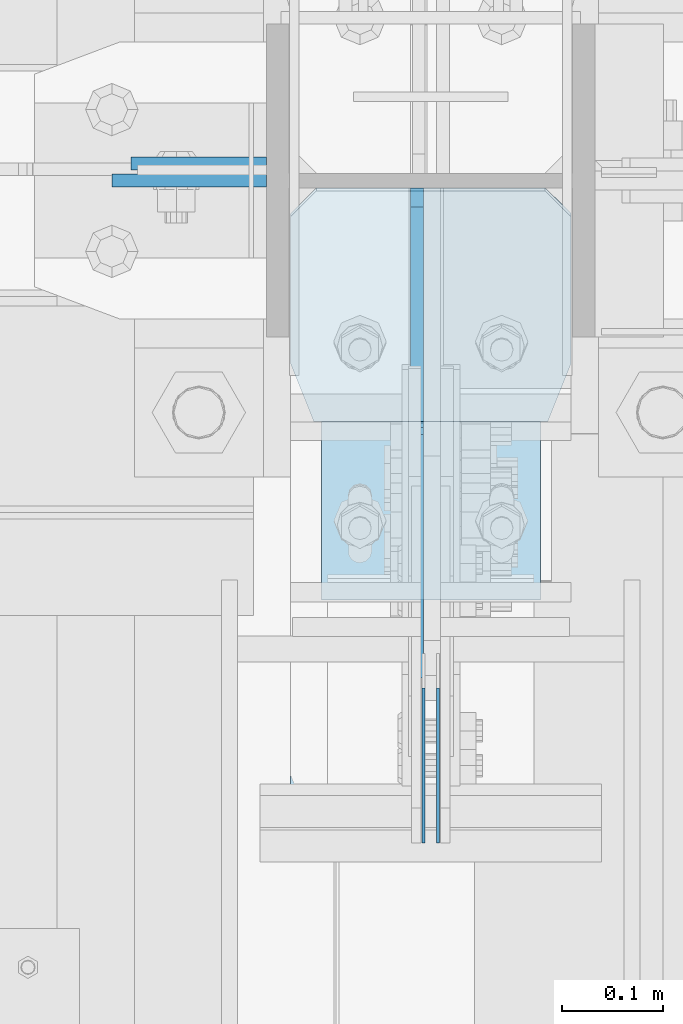
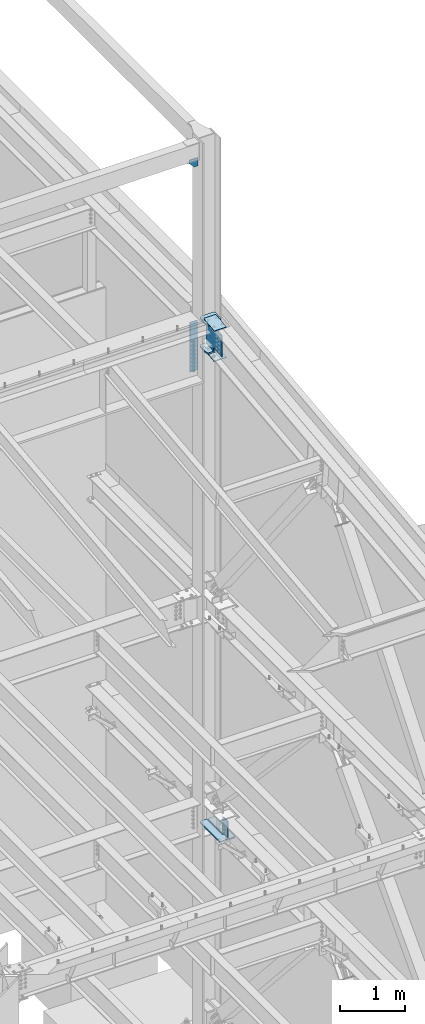
# One storey, part 1089 of 1179: 10 plates, 2 elements without a shape of their own.
"""IFC2X3 building model written with IfcOpenShell, lengths in millimetres."""

from ifc_helpers import new_model, si_unit, frame, origin_with_axes, place, context, subcontext, project, spatial, faceted_brep, material, type_object, element, aggregate, save


model = new_model("IFC2X3")

# Units and contexts
model_context = context("Model", 3, precision=1e-05, world=origin_with_axes())
body_context = subcontext(model_context, "Body", "Model", "MODEL_VIEW")
ifc_project = project(units=[si_unit("LENGTHUNIT", "METRE", prefix="MILLI"), si_unit("AREAUNIT", "SQUARE_METRE"), si_unit("VOLUMEUNIT", "CUBIC_METRE"), si_unit("MASSUNIT", "GRAM", prefix="KILO"), si_unit("TIMEUNIT", "SECOND"), si_unit("PLANEANGLEUNIT", "RADIAN"), si_unit("SOLIDANGLEUNIT", "STERADIAN"), si_unit("THERMODYNAMICTEMPERATUREUNIT", "DEGREE_CELSIUS"), si_unit("LUMINOUSINTENSITYUNIT", "LUMEN")], contexts=[model_context])

# Site, building, storey
site_placement = place(None, origin_with_axes())
site = spatial("IfcSite", under=ifc_project, at=site_placement, CompositionType="ELEMENT")
building_placement = place(site_placement, origin_with_axes())
building = spatial("IfcBuilding", under=site, at=building_placement, Name="Undefined", CompositionType="ELEMENT")
storey_placement = place(building_placement, origin_with_axes())
storey = spatial("IfcBuildingStorey", under=building, at=storey_placement, Name="Undefined", CompositionType="ELEMENT", Elevation=0.0)

# Assembly, plates
assembly_1_placement = place(storey_placement, origin_with_axes())
assembly_1 = element("IfcElementAssembly", 1, at=assembly_1_placement, inside=storey, Name="BEAM", AssemblyPlace="NOTDEFINED", PredefinedType="RIGID_FRAME")
ifc_material_1 = material(Name="STEEL/A572-GR.50")
plate_type_1 = type_object("IfcPlateType", PredefinedType="NOTDEFINED")
plate_1_placement = place(assembly_1_placement, frame((24300.65625, 33738.9169989339, 4044.95), z_axis=(0.0, 0.0, -1.0), x_axis=(0.0, 1.0, 0.0)))
plate_1 = element("IfcPlate", 2, at=plate_1_placement, type_object=plate_type_1, material=ifc_material_1, Name="PLATE", context=body_context, shape_type="Brep", body=[
    faceted_brep([(3.63797880709171e-12, -1.58750000000055, 1.81898940354586e-12), (-2.18278728425503e-11, -1.58750000000146, 304.8), (-2.18278728425503e-11, 1.58750000000146, 304.8), (-3.63797880709171e-12, 1.58750000000055, 0.0), (152.399999999994, -1.58750000000146, 304.8), (152.399999999994, 1.58750000000146, 304.8), (152.399999999994, -1.58750000000146, 0.0), (152.399999999994, 1.58750000000146, 0.0)], [[[0, 1, 2, 3]], [[1, 4, 5, 2]], [[4, 6, 7, 5]], [[6, 0, 3, 7]], [[5, 7, 3, 2]], [[6, 4, 1, 0]]]),
])
plate_2_placement = place(assembly_1_placement, frame((24314.94375, 33738.9169989339, 4044.95), z_axis=(0.0, 0.0, -1.0), x_axis=(0.0, 1.0, 0.0)))
plate_2 = element("IfcPlate", 3, at=plate_2_placement, type_object=plate_type_1, material=ifc_material_1, Name="PLATE", context=body_context, shape_type="Brep", body=[
    faceted_brep([(3.63797880709171e-12, -1.58750000000055, 1.81898940354586e-12), (-2.18278728425503e-11, -1.58750000000146, 304.8), (-2.18278728425503e-11, 1.58750000000146, 304.8), (-3.63797880709171e-12, 1.58750000000055, 0.0), (152.399999999994, -1.58750000000146, 304.8), (152.399999999994, 1.58750000000146, 304.8), (152.399999999994, -1.58750000000146, 0.0), (152.399999999994, 1.58750000000146, 0.0)], [[[0, 1, 2, 3]], [[1, 4, 5, 2]], [[4, 6, 7, 5]], [[6, 0, 3, 7]], [[5, 7, 3, 2]], [[6, 4, 1, 0]]]),
])
aggregate(assembly_1, [plate_1, plate_2])

assembly_2_placement = place(storey_placement, origin_with_axes())
assembly_2 = element("IfcElementAssembly", 4, at=assembly_2_placement, inside=storey, Name="COLUMN", AssemblyPlace="NOTDEFINED", PredefinedType="RIGID_FRAME")
ifc_material_2 = material(Name="STEEL/A36")
plate_type_2 = type_object("IfcPlateType", PredefinedType="NOTDEFINED")
plate_3_placement = place(assembly_2_placement, frame((23993.4750001183, 34391.6, 16109.95), z_axis=(1.0, 0.0, 0.0), x_axis=(0.0, 0.0, -1.0)))
plate_3 = element("IfcPlate", 5, at=plate_3_placement, type_object=plate_type_2, material=ifc_material_2, Name="PLATE", context=body_context, shape_type="Brep", body=[
    faceted_brep([(0.0, -6.34999999999854, 0.0), (0.0, -6.34999999999854, 152.400000000001), (0.0, 6.34999999999854, 152.400000000001), (0.0, 6.34999999999854, 0.0), (152.399993896484, -6.34999999999854, 152.399993896484), (152.399993896484, 6.34999999999854, 152.399993896484), (152.399993896484, -6.34999999999854, 88.6901931762695), (152.399993896484, 6.34999999999854, 88.6901931762695), (63.5, -6.34999999999854, 0.0), (63.5, 6.34999999999854, 0.0)], [[[0, 1, 2, 3]], [[1, 4, 5, 2]], [[4, 6, 7, 5]], [[6, 8, 9, 7]], [[8, 0, 3, 9]], [[5, 7, 9, 3, 2]], [[8, 6, 4, 1, 0]]]),
])
plate_type_3 = type_object("IfcPlateType", PredefinedType="NOTDEFINED")
plate_4_placement = place(assembly_2_placement, frame((24169.6874938965, 33751.6169989338, 3694.1125), z_axis=(0.0, 1.0, 0.0), x_axis=(1.0, 0.0, 0.0)))
plate_4 = element("IfcPlate", 6, at=plate_4_placement, type_object=plate_type_3, material=ifc_material_1, Name="PLATE", context=body_context, shape_type="Brep", body=[
    faceted_brep([(127.000006103513, -11.1125000000002, 632.839251066151), (127.000006103513, -11.1125000000002, 153.987500190735), (127.000006103513, 11.1125000000002, 153.987500190735), (127.000006103513, 11.1125000000002, 632.839251066151), (127.845894812999, -11.1125000000002, 149.734930475584), (127.845894812999, 11.1125000000002, 149.734930475584), (130.254782053442, -11.1125000000002, 146.129775949928), (130.254782053442, 11.1125000000002, 146.129775949928), (133.859936579101, -11.1125000000002, 143.720888709489), (133.859936579101, 11.1125000000002, 143.720888709489), (138.112505912784, -11.1125000000002, 142.875), (138.112505912784, 11.1125000000002, 142.875), (142.365075627931, -11.1125000000002, 143.720888709489), (142.365075627931, 11.1125000000002, 143.720888709489), (145.970230153591, -11.1125000000002, 146.129775949928), (145.970230153591, 11.1125000000002, 146.129775949928), (148.379117394034, -11.1125000000002, 149.734930475584), (148.379117394034, 11.1125000000002, 149.734930475584), (149.225006103519, -11.1125000000002, 153.987500190735), (149.225006103519, 11.1125000000002, 153.987500190735), (149.225006103519, -11.1125000000002, 632.839251066151), (149.225006103519, 11.1125000000002, 632.839251066151), (0.0, -11.1125000000002, 607.43925144762), (25.3999996185303, -11.1125000000002, 632.839251066151), (25.3999996185303, 11.1125000000002, 632.839251066151), (0.0, 11.1125000000002, 607.43925144762), (0.0, -11.1125000000002, 19.0499992370605), (0.0, 11.1125000000002, 19.0499992370605), (7.9375, -11.1125000000002, 0.0), (7.9375, 11.1125000000002, 0.0), (268.287506103516, -11.1125000000002, 0.0), (268.287506103516, 11.1125000000002, 0.0), (276.225006103516, -11.1125000000002, 19.0499992370605), (276.225006103516, 11.1125000000002, 19.0499992370605), (276.225006103516, -11.1125000000002, 607.43925144762), (276.225006103516, 11.1125000000002, 607.43925144762), (250.825006484985, -11.1125000000002, 632.839251066151), (250.825006484985, 11.1125000000002, 632.839251066151)], [[[0, 1, 2, 3]], [[4, 5, 2, 1]], [[6, 7, 5, 4]], [[8, 9, 7, 6]], [[10, 11, 9, 8]], [[12, 13, 11, 10]], [[14, 15, 13, 12]], [[16, 17, 15, 14]], [[18, 19, 17, 16]], [[20, 21, 19, 18]], [[22, 23, 24, 25]], [[26, 22, 25, 27]], [[28, 26, 27, 29]], [[30, 28, 29, 31]], [[32, 30, 31, 33]], [[34, 32, 33, 35]], [[36, 34, 35, 37]], [[16, 14, 12, 10, 8, 6, 4, 1, 0, 23, 22, 26, 28, 30, 32, 34, 36, 20, 18]], [[24, 23, 0, 3]], [[37, 35, 33, 31, 29, 27, 25, 24, 3, 2, 5, 7, 9, 11, 13, 15, 17, 19, 21]], [[36, 37, 21, 20]]]),
])
plate_type_4 = type_object("IfcPlateType", PredefinedType="NOTDEFINED")
plate_5_placement = place(assembly_2_placement, frame((24145.875, 34408.26875, 13061.95), z_axis=(-1.0, 0.0, 0.0), x_axis=(0.0, 0.0, -1.0)))
plate_5 = element("IfcPlate", 7, at=plate_5_placement, type_object=plate_type_4, material=ifc_material_2, Name="PLATE", context=body_context, shape_type="Brep", body=[
    faceted_brep([(0.0, -6.34999999999854, 0.0), (0.0, -6.34999999999854, 133.350000000002), (0.0, 6.34999999999854, 133.350000000002), (0.0, 6.34999999999854, 0.0), (927.1, -6.34999999999854, 133.350000000002), (927.1, 6.34999999999854, 133.350000000002), (927.1, -6.34999999999854, 0.0), (927.1, 6.34999999999854, 0.0)], [[[0, 1, 2, 3]], [[1, 4, 5, 2]], [[4, 6, 7, 5]], [[6, 0, 3, 7]], [[5, 7, 3, 2]], [[6, 4, 1, 0]]]),
])
plate_type_5 = type_object("IfcPlateType", PredefinedType="NOTDEFINED")
plate_6_placement = place(assembly_2_placement, frame((24199.8500030415, 33978.9392591768, 12527.2941552727), z_axis=(1.0, 0.0, 0.0), x_axis=(0.0, 0.993676146336441, 0.112284087038017)))
plate_6 = element("IfcPlate", 8, at=plate_6_placement, type_object=plate_type_5, material=ifc_material_1, Name="PLATE", context=body_context, shape_type="Brep", body=[
    faceted_brep([(0.0, -6.34999999999854, 0.0), (0.0, -6.350000000004, 215.899993896484), (0.0, 6.35000000000582, 215.899993896484), (0.0, 6.34999999999854, 0.0), (329.440285595374, -6.3499999999749, 215.899993896484), (329.440285595425, 6.35000000002765, 215.899993896484), (329.440285595374, -6.3499999999749, 0.0), (329.440285595425, 6.35000000002765, 0.0)], [[[0, 1, 2, 3]], [[1, 4, 5, 2]], [[4, 6, 7, 5]], [[6, 0, 3, 7]], [[5, 7, 3, 2]], [[6, 4, 1, 0]]]),
])
plate_7_placement = place(assembly_2_placement, frame((24199.8500030404, 33977.5132511952, 13092.6844834424), z_axis=(1.0, 0.0, 0.0), x_axis=(0.0, 0.993676146336441, 0.112284087038017)))
plate_7 = element("IfcPlate", 9, at=plate_7_placement, type_object=plate_type_5, material=ifc_material_1, Name="PLATE", context=body_context, shape_type="Brep", body=[
    faceted_brep([(0.0, -6.34999999999854, 0.0), (0.0, -6.350000000004, 215.899993896484), (0.0, 6.35000000000582, 215.899993896484), (0.0, 6.34999999999854, 0.0), (329.482022553479, -6.34999999995125, 215.899993896484), (329.4820225535, 6.3500000000422, 215.899993896484), (329.482022553479, -6.34999999995125, 0.0), (329.4820225535, 6.3500000000422, 0.0)], [[[0, 1, 2, 3]], [[1, 4, 5, 2]], [[4, 6, 7, 5]], [[6, 0, 3, 7]], [[5, 7, 3, 2]], [[6, 4, 1, 0]]]),
])
plate_type_6 = type_object("IfcPlateType", PredefinedType="NOTDEFINED")
plate_8_placement = place(assembly_2_placement, frame((24294.30625, 34384.4562499998, 12626.8279812055), z_axis=(0.0, -0.743858433013958, 0.668337214012522), x_axis=(0.0, -0.668337214012522, -0.743858433013957)))
plate_8 = element("IfcPlate", 10, at=plate_8_placement, type_object=plate_type_6, material=ifc_material_1, Name="PLATE", context=body_context, shape_type="Brep", body=[
    faceted_brep([(0.0, -6.34999999999854, 0.0), (-340.375392921102, -6.34999999999854, 305.818327405632), (-340.375392921102, 6.34999999999854, 305.818327405632), (0.0, 6.34999999999854, 0.0), (-340.212824076436, -6.34999999999854, 331.281975258757), (-340.212824076436, 6.34999999999854, 331.281975258757), (-181.389723418179, -6.34999999999854, 472.361832661933), (-181.389723418179, 6.34999999999854, 472.361832661933), (-179.502027274539, -6.34999999999854, 470.665787385737), (-179.502027274539, 6.34999999999854, 470.665787385737), (-172.144941562703, -6.34999999999854, 466.158289421121), (-172.144941562703, 6.34999999999854, 466.158289421121), (-163.664248872479, -6.34999999999854, 464.570177471011), (-163.664248872479, 6.34999999999854, 464.570177471011), (-155.174691935616, -6.34999999999854, 466.110200551342), (-155.174691935616, 6.34999999999854, 466.110200551342), (-147.792178642769, -6.34999999999854, 470.575930676783), (-147.792178642769, 6.34999999999854, 470.575930676783), (26.6432631811149, -6.34999999999854, 625.523965040669), (26.6432631811149, 6.34999999999854, 625.523965040669), (321.364099707622, -6.34999999999854, 360.725054330291), (321.364099707622, 6.34999999999854, 360.725054330291), (152.290193006287, -6.34999999999854, 210.539580371133), (152.290193006287, 6.34999999999854, 210.539580371133), (146.964028323098, -6.34999999999854, 203.901218701296), (146.964028323098, 6.34999999999854, 203.901218701296), (144.129778363444, -6.34999999999854, 195.87607676745), (144.129778363444, 6.34999999999854, 195.87607676745), (144.105660909729, -6.34999999999854, 187.36518408568), (144.105660909729, 6.34999999999854, 187.36518408568), (146.89438376922, -6.34999999999854, 179.324108243152), (146.89438376922, 6.34999999999854, 179.324108243152), (152.182840752732, -6.34999999999854, 172.655667748888), (152.182840752732, 6.34999999999854, 172.655667748888), (187.326675801443, -6.34999999999854, 141.079857403198), (187.326675801443, 6.34999999999854, 141.079857403198), (28.5035613092805, -6.35000000000002, -1.04591890703887e-11), (28.5035613092805, 6.35000000000002, -1.04591890703887e-11)], [[[0, 1, 2, 3]], [[1, 4, 5, 2]], [[4, 6, 7, 5]], [[6, 8, 9, 7]], [[8, 10, 11, 9]], [[10, 12, 13, 11]], [[12, 14, 15, 13]], [[14, 16, 17, 15]], [[16, 18, 19, 17]], [[18, 20, 21, 19]], [[20, 22, 23, 21]], [[22, 24, 25, 23]], [[24, 26, 27, 25]], [[26, 28, 29, 27]], [[28, 30, 31, 29]], [[30, 32, 33, 31]], [[32, 34, 35, 33]], [[34, 36, 37, 35]], [[36, 0, 3, 37]], [[5, 7, 9, 11, 13, 15, 17, 19, 21, 23, 25, 27, 29, 31, 33, 35, 37, 3, 2]], [[36, 34, 32, 30, 28, 26, 24, 22, 20, 18, 16, 14, 12, 10, 8, 6, 4, 1, 0]]]),
])
plate_type_7 = type_object("IfcPlateType", PredefinedType="NOTDEFINED")
plate_9_placement = place(assembly_2_placement, frame((24169.6875000014, 34149.3877805205, 12567.2325248612), z_axis=(1.0, 0.0, 0.0), x_axis=(0.0, 0.993676146336441, 0.112284087038017)))
plate_9 = element("IfcPlate", 11, at=plate_9_placement, type_object=plate_type_7, material=ifc_material_1, Name="PLATE", context=body_context, shape_type="Brep", body=[
    faceted_brep([(209.549999618157, -14.287499999904, 0.0), (63.5000000001965, -14.2875000000422, 0.0), (63.5000000002037, 14.2874999999422, 0.0), (209.549999618144, 14.2875000000804, 0.0), (234.950000001358, -14.2875000001823, 25.3999996185303), (234.950000001365, 14.2874999998021, 25.3999996185303), (234.950000007964, -14.2875000001823, 250.825000381337), (234.950000007979, 14.2874999998039, 250.825000381337), (209.550000390103, -14.2875000001604, 276.224999999868), (209.550000390111, 14.2874999998239, 276.224999999868), (63.5000000082873, -14.2875000000422, 276.224999999868), (63.5000000082946, 14.2874999999403, 276.224999999868), (6.57346774851612, 14.2874999999876, 253.454387438273), (3.34453063560795, -14.2874999999949, 252.162812612529), (3.34453063560795, -14.2874999999949, 24.0621873846649), (6.57346774851612, 14.2874999999876, 22.770612558892)], [[[0, 1, 2, 3]], [[4, 0, 3, 5]], [[6, 4, 5, 7]], [[8, 6, 7, 9]], [[10, 8, 9, 11]], [[10, 11, 12, 13]], [[1, 0, 4, 6, 8, 10, 13, 14]], [[2, 1, 14, 15]], [[11, 9, 7, 5, 3, 2, 15, 12]], [[14, 13, 12, 15]]]),
])
plate_10_placement = place(assembly_2_placement, frame((24169.6875000012, 34149.38778052, 13091.4281655017), z_axis=(1.0, 0.0, 0.0), x_axis=(0.0, 0.993676146336441, 0.112284087038017)))
plate_10 = element("IfcPlate", 12, at=plate_10_placement, type_object=plate_type_7, material=ifc_material_1, Name="PLATE", context=body_context, shape_type="Brep", body=[
    faceted_brep([(209.549999618157, -14.287499999904, 0.0), (63.5000000001965, -14.2875000000422, 0.0), (63.5000000002037, 14.2874999999422, 0.0), (209.549999618144, 14.2875000000804, 0.0), (234.950000001358, -14.2875000001823, 25.3999996185303), (234.950000001365, 14.2874999998021, 25.3999996185303), (234.950000007964, -14.2875000001823, 250.825000381337), (234.950000007979, 14.2874999998039, 250.825000381337), (209.550000390103, -14.2875000001604, 276.224999999868), (209.550000390111, 14.2874999998239, 276.224999999868), (63.5000000082873, -14.2875000000422, 276.224999999868), (63.5000000082946, 14.2874999999403, 276.224999999868), (6.57346774851612, 14.2874999999876, 253.454387438273), (3.34453063560795, -14.2874999999949, 252.162812612529), (3.34453063560795, -14.2874999999949, 24.0621873846649), (6.57346774851612, 14.2874999999876, 22.770612558892)], [[[0, 1, 2, 3]], [[4, 0, 3, 5]], [[6, 4, 5, 7]], [[8, 6, 7, 9]], [[10, 8, 9, 11]], [[10, 11, 12, 13]], [[1, 0, 4, 6, 8, 10, 13, 14]], [[2, 1, 14, 15]], [[11, 9, 7, 5, 3, 2, 15, 12]], [[14, 13, 12, 15]]]),
])
aggregate(assembly_2, [plate_3, plate_4, plate_5, plate_6, plate_7, plate_9, plate_10, plate_8])

save(model, "model.ifc")
